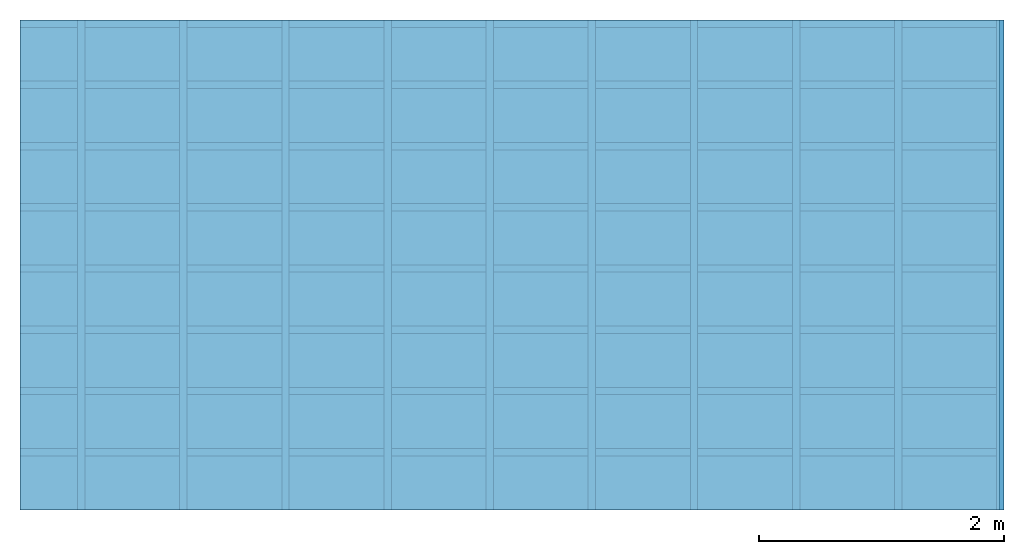
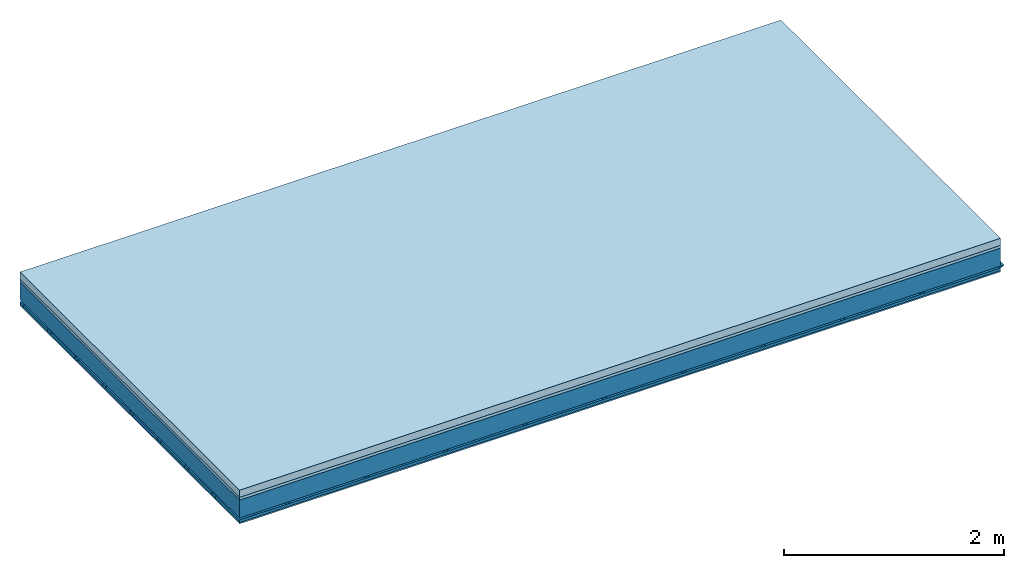
# One storey: 4 members, 3 plates, 1 element without a shape of its own.
"""IFC4 building model written with IfcOpenShell, lengths in metres."""

from ifc_helpers import new_model, si_unit, derived_unit, direction, frame, frame_2d, origin, origin_with_axes, place, context, project, spatial, polyline, rectangle, outline, extrude, material, layer, layer_set, type_object, element, aggregate, save


model = new_model("IFC4")

# Units and contexts
plan_context = context("Plan", 3, precision=1e-05, world=origin(), true_north=direction((0.0, 1.0)))
model_context = context("Model", 3, precision=1e-05, world=origin(), true_north=direction((0.0, 1.0)))
ifc_project = project(units=[si_unit("LENGTHUNIT", "METRE"), derived_unit("SOUNDPRESSUREUNIT", [(si_unit("PRESSUREUNIT", "PASCAL", prefix="MICRO"), 0)]), si_unit("ENERGYUNIT", "JOULE", prefix="MEGA"), si_unit("MASSUNIT", "GRAM", prefix="KILO"), derived_unit("THERMALTRANSMITTANCEUNIT", [(si_unit("POWERUNIT", "WATT"), 1), (si_unit("AREAUNIT", "SQUARE_METRE"), -1), (si_unit("THERMODYNAMICTEMPERATUREUNIT", "KELVIN"), -1)]), derived_unit("AREADENSITYUNIT", [(si_unit("MASSUNIT", "GRAM", prefix="KILO"), 1), (si_unit("AREAUNIT", "SQUARE_METRE"), -1)]), derived_unit("USERDEFINED", [(si_unit("ENERGYUNIT", "JOULE", prefix="MEGA"), 1), (si_unit("AREAUNIT", "SQUARE_METRE"), -1)])], contexts=[plan_context, model_context])

# Site, building, storey
site = spatial("IfcSite", under=ifc_project)
building_placement = place(None, origin())
building = spatial("IfcBuilding", under=site, at=building_placement)
storey_placement = place(building_placement, origin())
storey = spatial("IfcBuildingStorey", under=building, at=storey_placement)

# Slab, members, plates
ifc_material_1 = material(Name="Cement screed", Category="04.006")
ifc_layer_1 = layer(ifc_material_1, 0.08, Name="On-material")
ifc_material_2 = material()
ifc_layer_2 = layer(ifc_material_2, 0.03, Name="Impact sound insulation")
ifc_layer_3 = layer(None, 0.2, Name="Supporting structure")
ifc_material_3 = material(Name="no composite action")
ifc_layer_4 = layer(ifc_material_3, 0.0, Name="Bond")
ifc_layer_5 = layer(None, 0.02, Name="Coupling")
ifc_layer_6 = layer(None, 0.03, Name="Battens / profiles")
ifc_material_4 = material(Category="03.007")
ifc_layer_7 = layer(ifc_material_4, 0.015, Name="Ceiling covering 1st layer")
ifc_material_5 = material(Name="Glued joints")
ifc_layer_8 = layer(ifc_material_5, 0.0, Name="Surface / treatment")
ifc_layer_set = layer_set([ifc_layer_1, ifc_layer_2, ifc_layer_3, ifc_layer_4, ifc_layer_5, ifc_layer_6, ifc_layer_7, ifc_layer_8])
slab_type = type_object("IfcSlabType", Name="A0862", PredefinedType="NOTDEFINED", material=ifc_layer_set)
slab_placement = place(None, frame((0.0, 0.0, 0.0), z_axis=(0.0, 0.0, -1.0), x_axis=(1.0, 0.0, 0.0)))
slab = element("IfcSlab", 1, at=slab_placement, inside=storey, type_object=slab_type, material=ifc_layer_set, Name="Slab #1")
ifc_material_6 = material()
member_1_placement = place(slab_placement, origin())
member_1 = element("IfcMember", 2, at=member_1_placement, material=ifc_material_6, Name="Supporting structure", context=plan_context, shape_type="SweptSolid", body=[
    extrude(rectangle(XDim=1.0, YDim=0.2, at=frame_2d((0.5, 0.1), x_axis=(1.0, 0.0))), frame((0.0, 4.0, 0.11), z_axis=(0.0, -1.0, 0.0), x_axis=(1.0, 0.0, 0.0)), (0.0, 0.0, 1.0), 4.0),
    extrude(rectangle(XDim=1.0, YDim=0.2, at=frame_2d((0.5, 0.1), x_axis=(1.0, 0.0))), frame((1.0, 4.0, 0.11), z_axis=(0.0, -1.0, 0.0), x_axis=(1.0, 0.0, 0.0)), (0.0, 0.0, 1.0), 4.0),
    extrude(rectangle(XDim=1.0, YDim=0.2, at=frame_2d((0.5, 0.1), x_axis=(1.0, 0.0))), frame((2.0, 4.0, 0.11), z_axis=(0.0, -1.0, 0.0), x_axis=(1.0, 0.0, 0.0)), (0.0, 0.0, 1.0), 4.0),
    extrude(rectangle(XDim=1.0, YDim=0.2, at=frame_2d((0.5, 0.1), x_axis=(1.0, 0.0))), frame((3.0, 4.0, 0.11), z_axis=(0.0, -1.0, 0.0), x_axis=(1.0, 0.0, 0.0)), (0.0, 0.0, 1.0), 4.0),
    extrude(rectangle(XDim=1.0, YDim=0.2, at=frame_2d((0.5, 0.1), x_axis=(1.0, 0.0))), frame((4.0, 4.0, 0.11), z_axis=(0.0, -1.0, 0.0), x_axis=(1.0, 0.0, 0.0)), (0.0, 0.0, 1.0), 4.0),
    extrude(rectangle(XDim=1.0, YDim=0.2, at=frame_2d((0.5, 0.1), x_axis=(1.0, 0.0))), frame((5.0, 4.0, 0.11), z_axis=(0.0, -1.0, 0.0), x_axis=(1.0, 0.0, 0.0)), (0.0, 0.0, 1.0), 4.0),
    extrude(rectangle(XDim=1.0, YDim=0.2, at=frame_2d((0.5, 0.1), x_axis=(1.0, 0.0))), frame((6.0, 4.0, 0.11), z_axis=(0.0, -1.0, 0.0), x_axis=(1.0, 0.0, 0.0)), (0.0, 0.0, 1.0), 4.0),
    extrude(rectangle(XDim=1.0, YDim=0.2, at=frame_2d((0.5, 0.1), x_axis=(1.0, 0.0))), frame((7.0, 4.0, 0.11), z_axis=(0.0, -1.0, 0.0), x_axis=(1.0, 0.0, 0.0)), (0.0, 0.0, 1.0), 4.0),
])
ifc_material_7 = material()
member_2_placement = place(slab_placement, origin())
member_2 = element("IfcMember", 3, at=member_2_placement, material=ifc_material_7, Name="Coupling", context=plan_context, shape_type="SweptSolid", body=[
    extrude(outline(polyline([(0.0, 0.0), (0.06, 0.0), (0.04, 0.02), (0.02, 0.02), (0.0, 0.0)])), frame((0.47, 4.0, 0.31), z_axis=(0.0, -1.0, 0.0), x_axis=(1.0, 0.0, 0.0)), (0.0, 0.0, 1.0), 4.0),
    extrude(outline(polyline([(0.0, 0.0), (0.06, 0.0), (0.04, 0.02), (0.02, 0.02), (0.0, 0.0)])), frame((1.304, 4.0, 0.31), z_axis=(0.0, -1.0, 0.0), x_axis=(1.0, 0.0, 0.0)), (0.0, 0.0, 1.0), 4.0),
    extrude(outline(polyline([(0.0, 0.0), (0.06, 0.0), (0.04, 0.02), (0.02, 0.02), (0.0, 0.0)])), frame((2.138, 4.0, 0.31), z_axis=(0.0, -1.0, 0.0), x_axis=(1.0, 0.0, 0.0)), (0.0, 0.0, 1.0), 4.0),
    extrude(outline(polyline([(0.0, 0.0), (0.06, 0.0), (0.04, 0.02), (0.02, 0.02), (0.0, 0.0)])), frame((2.972, 4.0, 0.31), z_axis=(0.0, -1.0, 0.0), x_axis=(1.0, 0.0, 0.0)), (0.0, 0.0, 1.0), 4.0),
    extrude(outline(polyline([(0.0, 0.0), (0.06, 0.0), (0.04, 0.02), (0.02, 0.02), (0.0, 0.0)])), frame((3.806, 4.0, 0.31), z_axis=(0.0, -1.0, 0.0), x_axis=(1.0, 0.0, 0.0)), (0.0, 0.0, 1.0), 4.0),
    extrude(outline(polyline([(0.0, 0.0), (0.06, 0.0), (0.04, 0.02), (0.02, 0.02), (0.0, 0.0)])), frame((4.64, 4.0, 0.31), z_axis=(0.0, -1.0, 0.0), x_axis=(1.0, 0.0, 0.0)), (0.0, 0.0, 1.0), 4.0),
    extrude(outline(polyline([(0.0, 0.0), (0.06, 0.0), (0.04, 0.02), (0.02, 0.02), (0.0, 0.0)])), frame((5.474, 4.0, 0.31), z_axis=(0.0, -1.0, 0.0), x_axis=(1.0, 0.0, 0.0)), (0.0, 0.0, 1.0), 4.0),
    extrude(outline(polyline([(0.0, 0.0), (0.06, 0.0), (0.04, 0.02), (0.02, 0.02), (0.0, 0.0)])), frame((6.308, 4.0, 0.31), z_axis=(0.0, -1.0, 0.0), x_axis=(1.0, 0.0, 0.0)), (0.0, 0.0, 1.0), 4.0),
    extrude(outline(polyline([(0.0, 0.0), (0.06, 0.0), (0.04, 0.02), (0.02, 0.02), (0.0, 0.0)])), frame((7.142, 4.0, 0.31), z_axis=(0.0, -1.0, 0.0), x_axis=(1.0, 0.0, 0.0)), (0.0, 0.0, 1.0), 4.0),
    extrude(outline(polyline([(0.0, 0.0), (0.06, 0.0), (0.04, 0.02), (0.02, 0.02), (0.0, 0.0)])), frame((7.976, 4.0, 0.31), z_axis=(0.0, -1.0, 0.0), x_axis=(1.0, 0.0, 0.0)), (0.0, 0.0, 1.0), 4.0),
])
ifc_material_8 = material()
member_3_placement = place(slab_placement, origin())
member_3 = element("IfcMember", 4, at=member_3_placement, material=ifc_material_8, Name="Battens / profiles", context=plan_context, shape_type="SweptSolid", body=[
    extrude(rectangle(XDim=0.06, YDim=0.03, at=frame_2d((0.03, 0.015), x_axis=(1.0, 0.0))), frame((0.0, 0.0, 0.33), z_axis=(1.0, 0.0, 0.0), x_axis=(0.0, 1.0, 0.0)), (0.0, 0.0, 1.0), 8.0),
    extrude(rectangle(XDim=0.06, YDim=0.03, at=frame_2d((0.03, 0.015), x_axis=(1.0, 0.0))), frame((0.0, 0.5, 0.33), z_axis=(1.0, 0.0, 0.0), x_axis=(0.0, 1.0, 0.0)), (0.0, 0.0, 1.0), 8.0),
    extrude(rectangle(XDim=0.06, YDim=0.03, at=frame_2d((0.03, 0.015), x_axis=(1.0, 0.0))), frame((0.0, 1.0, 0.33), z_axis=(1.0, 0.0, 0.0), x_axis=(0.0, 1.0, 0.0)), (0.0, 0.0, 1.0), 8.0),
    extrude(rectangle(XDim=0.06, YDim=0.03, at=frame_2d((0.03, 0.015), x_axis=(1.0, 0.0))), frame((0.0, 1.5, 0.33), z_axis=(1.0, 0.0, 0.0), x_axis=(0.0, 1.0, 0.0)), (0.0, 0.0, 1.0), 8.0),
    extrude(rectangle(XDim=0.06, YDim=0.03, at=frame_2d((0.03, 0.015), x_axis=(1.0, 0.0))), frame((0.0, 2.0, 0.33), z_axis=(1.0, 0.0, 0.0), x_axis=(0.0, 1.0, 0.0)), (0.0, 0.0, 1.0), 8.0),
    extrude(rectangle(XDim=0.06, YDim=0.03, at=frame_2d((0.03, 0.015), x_axis=(1.0, 0.0))), frame((0.0, 2.5, 0.33), z_axis=(1.0, 0.0, 0.0), x_axis=(0.0, 1.0, 0.0)), (0.0, 0.0, 1.0), 8.0),
    extrude(rectangle(XDim=0.06, YDim=0.03, at=frame_2d((0.03, 0.015), x_axis=(1.0, 0.0))), frame((0.0, 3.0, 0.33), z_axis=(1.0, 0.0, 0.0), x_axis=(0.0, 1.0, 0.0)), (0.0, 0.0, 1.0), 8.0),
    extrude(rectangle(XDim=0.06, YDim=0.03, at=frame_2d((0.03, 0.015), x_axis=(1.0, 0.0))), frame((0.0, 3.5, 0.33), z_axis=(1.0, 0.0, 0.0), x_axis=(0.0, 1.0, 0.0)), (0.0, 0.0, 1.0), 8.0),
])
ifc_material_9 = material()
member_4_placement = place(slab_placement, origin())
member_4 = element("IfcMember", 5, at=member_4_placement, material=ifc_material_9, Name="Cavity", context=plan_context, shape_type="SweptSolid", body=[
    extrude(rectangle(XDim=0.44, YDim=0.03, at=frame_2d((0.22, 0.015), x_axis=(1.0, 0.0))), frame((0.0, 0.06, 0.33), z_axis=(1.0, 0.0, 0.0), x_axis=(0.0, 1.0, 0.0)), (0.0, 0.0, 1.0), 8.0),
    extrude(rectangle(XDim=0.44, YDim=0.03, at=frame_2d((0.22, 0.015), x_axis=(1.0, 0.0))), frame((0.0, 0.56, 0.33), z_axis=(1.0, 0.0, 0.0), x_axis=(0.0, 1.0, 0.0)), (0.0, 0.0, 1.0), 8.0),
    extrude(rectangle(XDim=0.44, YDim=0.03, at=frame_2d((0.22, 0.015), x_axis=(1.0, 0.0))), frame((0.0, 1.06, 0.33), z_axis=(1.0, 0.0, 0.0), x_axis=(0.0, 1.0, 0.0)), (0.0, 0.0, 1.0), 8.0),
    extrude(rectangle(XDim=0.44, YDim=0.03, at=frame_2d((0.22, 0.015), x_axis=(1.0, 0.0))), frame((0.0, 1.56, 0.33), z_axis=(1.0, 0.0, 0.0), x_axis=(0.0, 1.0, 0.0)), (0.0, 0.0, 1.0), 8.0),
    extrude(rectangle(XDim=0.44, YDim=0.03, at=frame_2d((0.22, 0.015), x_axis=(1.0, 0.0))), frame((0.0, 2.06, 0.33), z_axis=(1.0, 0.0, 0.0), x_axis=(0.0, 1.0, 0.0)), (0.0, 0.0, 1.0), 8.0),
    extrude(rectangle(XDim=0.44, YDim=0.03, at=frame_2d((0.22, 0.015), x_axis=(1.0, 0.0))), frame((0.0, 2.56, 0.33), z_axis=(1.0, 0.0, 0.0), x_axis=(0.0, 1.0, 0.0)), (0.0, 0.0, 1.0), 8.0),
    extrude(rectangle(XDim=0.44, YDim=0.03, at=frame_2d((0.22, 0.015), x_axis=(1.0, 0.0))), frame((0.0, 3.06, 0.33), z_axis=(1.0, 0.0, 0.0), x_axis=(0.0, 1.0, 0.0)), (0.0, 0.0, 1.0), 8.0),
    extrude(rectangle(XDim=0.44, YDim=0.03, at=frame_2d((0.22, 0.015), x_axis=(1.0, 0.0))), frame((0.0, 3.56, 0.33), z_axis=(1.0, 0.0, 0.0), x_axis=(0.0, 1.0, 0.0)), (0.0, 0.0, 1.0), 8.0),
])
plate_1_placement = place(slab_placement, origin())
plate_1 = element("IfcPlate", 6, at=plate_1_placement, material=ifc_material_1, Name="On-material", context=plan_context, shape_type="SweptSolid", body=[
    extrude(rectangle(XDim=8.0, YDim=4.0, at=frame_2d((4.0, 2.0), x_axis=(1.0, 0.0))), origin_with_axes(), (0.0, 0.0, 1.0), 0.08),
])
plate_2_placement = place(slab_placement, origin())
plate_2 = element("IfcPlate", 7, at=plate_2_placement, material=ifc_material_2, Name="Impact sound insulation", context=plan_context, shape_type="SweptSolid", body=[
    extrude(rectangle(XDim=8.0, YDim=4.0, at=frame_2d((4.0, 2.0), x_axis=(1.0, 0.0))), frame((0.0, 0.0, 0.08), z_axis=(0.0, 0.0, 1.0), x_axis=(1.0, 0.0, 0.0)), (0.0, 0.0, 1.0), 0.03),
])
plate_3_placement = place(slab_placement, origin())
plate_3 = element("IfcPlate", 8, at=plate_3_placement, material=ifc_material_4, Name="Ceiling covering 1st layer", context=plan_context, shape_type="SweptSolid", body=[
    extrude(rectangle(XDim=8.0, YDim=4.0, at=frame_2d((4.0, 2.0), x_axis=(1.0, 0.0))), frame((0.0, 0.0, 0.36), z_axis=(0.0, 0.0, 1.0), x_axis=(1.0, 0.0, 0.0)), (0.0, 0.0, 1.0), 0.015),
])
aggregate(slab, [plate_1, plate_2, member_1, member_2, member_3, member_4, plate_3])

save(model, "model.ifc")
